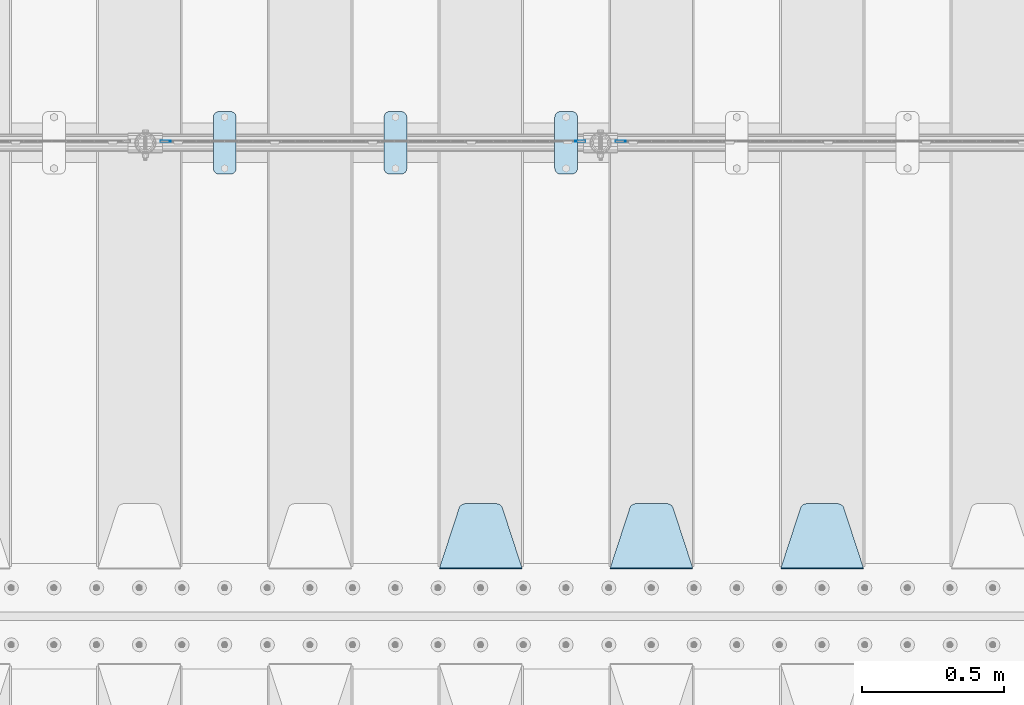
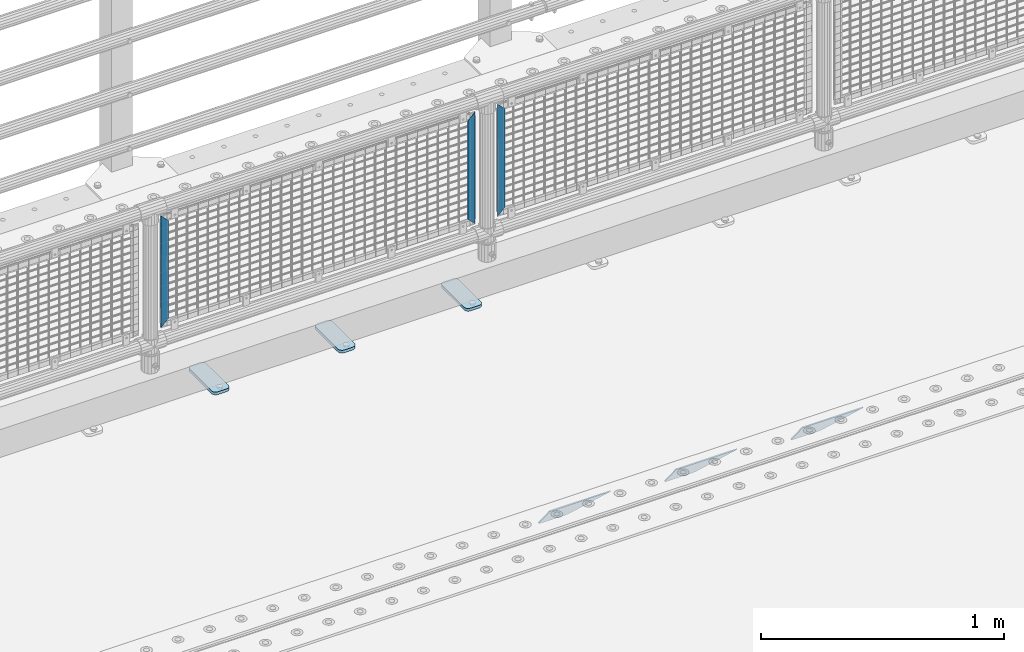
# One storey, part 225 of 257: 9 plates.
"""IFC2X3 building model written with IfcOpenShell, lengths in millimetres."""

from ifc_helpers import new_model, si_unit, frame, origin_with_axes, place, context, subcontext, project, spatial, faceted_brep, material, type_object, element, save


model = new_model("IFC2X3")

# Units and contexts
model_context = context("Model", 3, precision=1e-05, world=origin_with_axes())
body_context = subcontext(model_context, "Body", "Model", "MODEL_VIEW")
ifc_project = project(units=[si_unit("LENGTHUNIT", "METRE", prefix="MILLI"), si_unit("AREAUNIT", "SQUARE_METRE"), si_unit("VOLUMEUNIT", "CUBIC_METRE"), si_unit("MASSUNIT", "GRAM", prefix="KILO"), si_unit("TIMEUNIT", "SECOND"), si_unit("PLANEANGLEUNIT", "RADIAN"), si_unit("SOLIDANGLEUNIT", "STERADIAN"), si_unit("THERMODYNAMICTEMPERATUREUNIT", "DEGREE_CELSIUS"), si_unit("LUMINOUSINTENSITYUNIT", "LUMEN")], contexts=[model_context])

# Site, building, storey
site_placement = place(None, origin_with_axes())
site = spatial("IfcSite", under=ifc_project, at=site_placement, CompositionType="ELEMENT")
building_placement = place(site_placement, origin_with_axes())
building = spatial("IfcBuilding", under=site, at=building_placement, Name="Standard", CompositionType="ELEMENT")
storey_placement = place(building_placement, origin_with_axes())
storey = spatial("IfcBuildingStorey", under=building, at=storey_placement, Name="Undefined", CompositionType="ELEMENT", Elevation=0.0)

# Plates
ifc_material_1 = material(Name="STEEL/S355J2")
plate_type_1 = type_object("IfcPlateType", PredefinedType="NOTDEFINED")
plate_1_placement = place(storey_placement, frame((50910.0, 10774.5, 21.0199999999977), z_axis=(1.0, 0.0, 0.0), x_axis=(0.0, -1.0, 0.0)))
element("IfcPlate", 1, at=plate_1_placement, inside=storey, type_object=plate_type_1, material=ifc_material_1, context=body_context, shape_type="Brep", body=[
    faceted_brep([(0.0, -7.0, 20.0), (0.0, -7.0, 60.0), (0.0, 7.0, 60.0), (0.0, 7.0, 20.0), (0.384294391935327, -7.0, 63.9018064403208), (0.384294391935327, 7.0, 63.9018064403208), (1.52240934977453, -7.0, 67.6536686473046), (1.52240934977453, 7.0, 67.6536686473046), (3.37060775394821, -7.0, 71.1114046603907), (3.37060775394821, 7.0, 71.1114046603907), (5.85786437626848, -7.0, 74.1421356237333), (5.85786437626848, 7.0, 74.1421356237333), (8.88859533960749, -7.0, 76.6293922460536), (8.88859533960749, 7.0, 76.6293922460536), (12.3463313526991, -7.0, 78.4775906502255), (12.3463313526991, 7.0, 78.4775906502255), (16.0981935596774, -7.0, 79.6157056080629), (16.0981935596774, 7.0, 79.6157056080629), (20.0, -7.0, 80.0), (20.0, 7.0, 80.0), (200.0, -7.0, 80.0), (200.0, 7.0, 80.0), (203.901806440323, -7.0, 79.6157056080629), (203.901806440323, 7.0, 79.6157056080629), (207.653668647301, -7.0, 78.4775906502255), (207.653668647301, 7.0, 78.4775906502255), (211.111404660393, -7.0, 76.6293922460536), (211.111404660393, 7.0, 76.6293922460536), (214.142135623732, -7.0, 74.1421356237333), (214.142135623732, 7.0, 74.1421356237333), (216.629392246052, -7.0, 71.1114046603907), (216.629392246052, 7.0, 71.1114046603907), (218.477590650225, -7.0, 67.6536686473046), (218.477590650225, 7.0, 67.6536686473046), (219.615705608065, -7.0, 63.9018064403208), (219.615705608065, 7.0, 63.9018064403208), (220.0, -7.0, 60.0), (220.0, 7.0, 60.0), (220.0, -7.0, 20.0), (220.0, 7.0, 20.0), (219.615705608065, -7.0, 16.0981935596792), (219.615705608065, 7.0, 16.0981935596792), (218.477590650225, -7.0, 12.3463313526954), (218.477590650225, 7.0, 12.3463313526954), (216.629392246052, -7.0, 8.88859533960931), (216.629392246052, 7.0, 8.88859533960931), (214.142135623732, -7.0, 5.85786437626666), (214.142135623732, 7.0, 5.85786437626666), (211.111404660393, -7.0, 3.37060775394639), (211.111404660393, 7.0, 3.37060775394639), (207.653668647301, -7.0, 1.52240934977453), (207.653668647301, 7.0, 1.52240934977453), (203.901806440323, -7.0, 0.384294391937146), (203.901806440323, 7.0, 0.384294391937146), (200.0, -7.0, 0.0), (200.0, 7.0, 0.0), (20.0, -7.0, 0.0), (20.0, 7.0, 0.0), (16.0981935596774, -7.0, 0.384294391937146), (16.0981935596774, 7.0, 0.384294391937146), (12.3463313526991, -7.0, 1.52240934977453), (12.3463313526991, 7.0, 1.52240934977453), (8.88859533960749, -7.0, 3.37060775394639), (8.88859533960749, 7.0, 3.37060775394639), (5.85786437626848, -7.0, 5.85786437626666), (5.85786437626848, 7.0, 5.85786437626666), (3.37060775394821, -7.0, 8.88859533960931), (3.37060775394821, 7.0, 8.88859533960931), (1.52240934977453, -7.0, 12.3463313526954), (1.52240934977453, 7.0, 12.3463313526954), (0.384294391935327, -7.0, 16.0981935596792), (0.384294391935327, 7.0, 16.0981935596792)], [[[0, 1, 2, 3]], [[1, 4, 5, 2]], [[4, 6, 7, 5]], [[6, 8, 9, 7]], [[8, 10, 11, 9]], [[10, 12, 13, 11]], [[12, 14, 15, 13]], [[14, 16, 17, 15]], [[16, 18, 19, 17]], [[18, 20, 21, 19]], [[20, 22, 23, 21]], [[22, 24, 25, 23]], [[24, 26, 27, 25]], [[26, 28, 29, 27]], [[28, 30, 31, 29]], [[30, 32, 33, 31]], [[32, 34, 35, 33]], [[34, 36, 37, 35]], [[36, 38, 39, 37]], [[38, 40, 41, 39]], [[40, 42, 43, 41]], [[42, 44, 45, 43]], [[44, 46, 47, 45]], [[46, 48, 49, 47]], [[48, 50, 51, 49]], [[50, 52, 53, 51]], [[52, 54, 55, 53]], [[54, 56, 57, 55]], [[56, 58, 59, 57]], [[58, 60, 61, 59]], [[60, 62, 63, 61]], [[62, 64, 65, 63]], [[64, 66, 67, 65]], [[66, 68, 69, 67]], [[68, 70, 71, 69]], [[70, 0, 3, 71]], [[5, 7, 9, 11, 13, 15, 17, 19, 21, 23, 25, 27, 29, 31, 33, 35, 37, 39, 41, 43, 45, 47, 49, 51, 53, 55, 57, 59, 61, 63, 65, 67, 69, 71, 3, 2]], [[70, 68, 66, 64, 62, 60, 58, 56, 54, 52, 50, 48, 46, 44, 42, 40, 38, 36, 34, 32, 30, 28, 26, 24, 22, 20, 18, 16, 14, 12, 10, 8, 6, 4, 1, 0]]]),
])
plate_2_placement = place(storey_placement, frame((50310.0, 10774.5, 21.0199999999977), z_axis=(1.0, 0.0, 0.0), x_axis=(0.0, -1.0, 0.0)))
element("IfcPlate", 2, at=plate_2_placement, inside=storey, type_object=plate_type_1, material=ifc_material_1, context=body_context, shape_type="Brep", body=[
    faceted_brep([(0.0, -7.0, 20.0), (0.0, -7.0, 60.0), (0.0, 7.0, 60.0), (0.0, 7.0, 20.0), (0.384294391935327, -7.0, 63.9018064403208), (0.384294391935327, 7.0, 63.9018064403208), (1.52240934977453, -7.0, 67.6536686473046), (1.52240934977453, 7.0, 67.6536686473046), (3.37060775394821, -7.0, 71.1114046603907), (3.37060775394821, 7.0, 71.1114046603907), (5.85786437626848, -7.0, 74.1421356237333), (5.85786437626848, 7.0, 74.1421356237333), (8.88859533960749, -7.0, 76.6293922460536), (8.88859533960749, 7.0, 76.6293922460536), (12.3463313526991, -7.0, 78.4775906502255), (12.3463313526991, 7.0, 78.4775906502255), (16.0981935596774, -7.0, 79.6157056080629), (16.0981935596774, 7.0, 79.6157056080629), (20.0, -7.0, 80.0), (20.0, 7.0, 80.0), (200.0, -7.0, 80.0), (200.0, 7.0, 80.0), (203.901806440323, -7.0, 79.6157056080629), (203.901806440323, 7.0, 79.6157056080629), (207.653668647301, -7.0, 78.4775906502255), (207.653668647301, 7.0, 78.4775906502255), (211.111404660393, -7.0, 76.6293922460536), (211.111404660393, 7.0, 76.6293922460536), (214.142135623732, -7.0, 74.1421356237333), (214.142135623732, 7.0, 74.1421356237333), (216.629392246052, -7.0, 71.1114046603907), (216.629392246052, 7.0, 71.1114046603907), (218.477590650225, -7.0, 67.6536686473046), (218.477590650225, 7.0, 67.6536686473046), (219.615705608065, -7.0, 63.9018064403208), (219.615705608065, 7.0, 63.9018064403208), (220.0, -7.0, 60.0), (220.0, 7.0, 60.0), (220.0, -7.0, 20.0), (220.0, 7.0, 20.0), (219.615705608065, -7.0, 16.0981935596792), (219.615705608065, 7.0, 16.0981935596792), (218.477590650225, -7.0, 12.3463313526954), (218.477590650225, 7.0, 12.3463313526954), (216.629392246052, -7.0, 8.88859533960931), (216.629392246052, 7.0, 8.88859533960931), (214.142135623732, -7.0, 5.85786437626666), (214.142135623732, 7.0, 5.85786437626666), (211.111404660393, -7.0, 3.37060775394639), (211.111404660393, 7.0, 3.37060775394639), (207.653668647301, -7.0, 1.52240934977453), (207.653668647301, 7.0, 1.52240934977453), (203.901806440323, -7.0, 0.384294391937146), (203.901806440323, 7.0, 0.384294391937146), (200.0, -7.0, 0.0), (200.0, 7.0, 0.0), (20.0, -7.0, 0.0), (20.0, 7.0, 0.0), (16.0981935596774, -7.0, 0.384294391937146), (16.0981935596774, 7.0, 0.384294391937146), (12.3463313526991, -7.0, 1.52240934977453), (12.3463313526991, 7.0, 1.52240934977453), (8.88859533960749, -7.0, 3.37060775394639), (8.88859533960749, 7.0, 3.37060775394639), (5.85786437626848, -7.0, 5.85786437626666), (5.85786437626848, 7.0, 5.85786437626666), (3.37060775394821, -7.0, 8.88859533960931), (3.37060775394821, 7.0, 8.88859533960931), (1.52240934977453, -7.0, 12.3463313526954), (1.52240934977453, 7.0, 12.3463313526954), (0.384294391935327, -7.0, 16.0981935596792), (0.384294391935327, 7.0, 16.0981935596792)], [[[0, 1, 2, 3]], [[1, 4, 5, 2]], [[4, 6, 7, 5]], [[6, 8, 9, 7]], [[8, 10, 11, 9]], [[10, 12, 13, 11]], [[12, 14, 15, 13]], [[14, 16, 17, 15]], [[16, 18, 19, 17]], [[18, 20, 21, 19]], [[20, 22, 23, 21]], [[22, 24, 25, 23]], [[24, 26, 27, 25]], [[26, 28, 29, 27]], [[28, 30, 31, 29]], [[30, 32, 33, 31]], [[32, 34, 35, 33]], [[34, 36, 37, 35]], [[36, 38, 39, 37]], [[38, 40, 41, 39]], [[40, 42, 43, 41]], [[42, 44, 45, 43]], [[44, 46, 47, 45]], [[46, 48, 49, 47]], [[48, 50, 51, 49]], [[50, 52, 53, 51]], [[52, 54, 55, 53]], [[54, 56, 57, 55]], [[56, 58, 59, 57]], [[58, 60, 61, 59]], [[60, 62, 63, 61]], [[62, 64, 65, 63]], [[64, 66, 67, 65]], [[66, 68, 69, 67]], [[68, 70, 71, 69]], [[70, 0, 3, 71]], [[5, 7, 9, 11, 13, 15, 17, 19, 21, 23, 25, 27, 29, 31, 33, 35, 37, 39, 41, 43, 45, 47, 49, 51, 53, 55, 57, 59, 61, 63, 65, 67, 69, 71, 3, 2]], [[70, 68, 66, 64, 62, 60, 58, 56, 54, 52, 50, 48, 46, 44, 42, 40, 38, 36, 34, 32, 30, 28, 26, 24, 22, 20, 18, 16, 14, 12, 10, 8, 6, 4, 1, 0]]]),
])
plate_3_placement = place(storey_placement, frame((49710.0, 10774.5, 21.0199999999977), z_axis=(1.0, 0.0, 0.0), x_axis=(0.0, -1.0, 0.0)))
element("IfcPlate", 3, at=plate_3_placement, inside=storey, type_object=plate_type_1, material=ifc_material_1, context=body_context, shape_type="Brep", body=[
    faceted_brep([(0.0, -7.0, 20.0), (0.0, -7.0, 60.0), (0.0, 7.0, 60.0), (0.0, 7.0, 20.0), (0.384294391935327, -7.0, 63.9018064403208), (0.384294391935327, 7.0, 63.9018064403208), (1.52240934977453, -7.0, 67.6536686473046), (1.52240934977453, 7.0, 67.6536686473046), (3.37060775394821, -7.0, 71.1114046603907), (3.37060775394821, 7.0, 71.1114046603907), (5.85786437626848, -7.0, 74.1421356237333), (5.85786437626848, 7.0, 74.1421356237333), (8.88859533960749, -7.0, 76.6293922460536), (8.88859533960749, 7.0, 76.6293922460536), (12.3463313526991, -7.0, 78.4775906502255), (12.3463313526991, 7.0, 78.4775906502255), (16.0981935596774, -7.0, 79.6157056080629), (16.0981935596774, 7.0, 79.6157056080629), (20.0, -7.0, 80.0), (20.0, 7.0, 80.0), (200.0, -7.0, 80.0), (200.0, 7.0, 80.0), (203.901806440323, -7.0, 79.6157056080629), (203.901806440323, 7.0, 79.6157056080629), (207.653668647301, -7.0, 78.4775906502255), (207.653668647301, 7.0, 78.4775906502255), (211.111404660393, -7.0, 76.6293922460536), (211.111404660393, 7.0, 76.6293922460536), (214.142135623732, -7.0, 74.1421356237333), (214.142135623732, 7.0, 74.1421356237333), (216.629392246052, -7.0, 71.1114046603907), (216.629392246052, 7.0, 71.1114046603907), (218.477590650225, -7.0, 67.6536686473046), (218.477590650225, 7.0, 67.6536686473046), (219.615705608065, -7.0, 63.9018064403208), (219.615705608065, 7.0, 63.9018064403208), (220.0, -7.0, 60.0), (220.0, 7.0, 60.0), (220.0, -7.0, 20.0), (220.0, 7.0, 20.0), (219.615705608065, -7.0, 16.0981935596792), (219.615705608065, 7.0, 16.0981935596792), (218.477590650225, -7.0, 12.3463313526954), (218.477590650225, 7.0, 12.3463313526954), (216.629392246052, -7.0, 8.88859533960931), (216.629392246052, 7.0, 8.88859533960931), (214.142135623732, -7.0, 5.85786437626666), (214.142135623732, 7.0, 5.85786437626666), (211.111404660393, -7.0, 3.37060775394639), (211.111404660393, 7.0, 3.37060775394639), (207.653668647301, -7.0, 1.52240934977453), (207.653668647301, 7.0, 1.52240934977453), (203.901806440323, -7.0, 0.384294391937146), (203.901806440323, 7.0, 0.384294391937146), (200.0, -7.0, 0.0), (200.0, 7.0, 0.0), (20.0, -7.0, 0.0), (20.0, 7.0, 0.0), (16.0981935596774, -7.0, 0.384294391937146), (16.0981935596774, 7.0, 0.384294391937146), (12.3463313526991, -7.0, 1.52240934977453), (12.3463313526991, 7.0, 1.52240934977453), (8.88859533960749, -7.0, 3.37060775394639), (8.88859533960749, 7.0, 3.37060775394639), (5.85786437626848, -7.0, 5.85786437626666), (5.85786437626848, 7.0, 5.85786437626666), (3.37060775394821, -7.0, 8.88859533960931), (3.37060775394821, 7.0, 8.88859533960931), (1.52240934977453, -7.0, 12.3463313526954), (1.52240934977453, 7.0, 12.3463313526954), (0.384294391935327, -7.0, 16.0981935596792), (0.384294391935327, 7.0, 16.0981935596792)], [[[0, 1, 2, 3]], [[1, 4, 5, 2]], [[4, 6, 7, 5]], [[6, 8, 9, 7]], [[8, 10, 11, 9]], [[10, 12, 13, 11]], [[12, 14, 15, 13]], [[14, 16, 17, 15]], [[16, 18, 19, 17]], [[18, 20, 21, 19]], [[20, 22, 23, 21]], [[22, 24, 25, 23]], [[24, 26, 27, 25]], [[26, 28, 29, 27]], [[28, 30, 31, 29]], [[30, 32, 33, 31]], [[32, 34, 35, 33]], [[34, 36, 37, 35]], [[36, 38, 39, 37]], [[38, 40, 41, 39]], [[40, 42, 43, 41]], [[42, 44, 45, 43]], [[44, 46, 47, 45]], [[46, 48, 49, 47]], [[48, 50, 51, 49]], [[50, 52, 53, 51]], [[52, 54, 55, 53]], [[54, 56, 57, 55]], [[56, 58, 59, 57]], [[58, 60, 61, 59]], [[60, 62, 63, 61]], [[62, 64, 65, 63]], [[64, 66, 67, 65]], [[66, 68, 69, 67]], [[68, 70, 71, 69]], [[70, 0, 3, 71]], [[5, 7, 9, 11, 13, 15, 17, 19, 21, 23, 25, 27, 29, 31, 33, 35, 37, 39, 41, 43, 45, 47, 49, 51, 53, 55, 57, 59, 61, 63, 65, 67, 69, 71, 3, 2]], [[70, 68, 66, 64, 62, 60, 58, 56, 54, 52, 50, 48, 46, 44, 42, 40, 38, 36, 34, 32, 30, 28, 26, 24, 22, 20, 18, 16, 14, 12, 10, 8, 6, 4, 1, 0]]]),
])
ifc_material_2 = material(Name="STEEL/S355N")
plate_type_2 = type_object("IfcPlateType", PredefinedType="NOTDEFINED")
plate_4_placement = place(storey_placement, frame((51995.0, 9168.23223304703, -1.76776695296758), z_axis=(0.0, 0.707106781186547, -0.707106781186548), x_axis=(-1.0, 0.0, 0.0)))
element("IfcPlate", 4, at=plate_4_placement, inside=storey, type_object=plate_type_2, material=ifc_material_2, context=body_context, shape_type="Brep", body=[
    faceted_brep([(0.0, -2.5, 0.0), (69.345504679477, -2.50000000000091, 300.17173142483), (69.345504679477, 2.5, 300.171731424831), (0.0, 2.5, 0.0), (70.927406119954, -2.50000000000091, 304.8974424154), (70.927406119954, 2.5, 304.8974424154), (73.3818627772271, -2.50000000000091, 309.234538108527), (73.3818627772271, 2.49999999999909, 309.234538108527), (76.6187032999587, -2.5, 313.023683126103), (76.6187032999587, 2.5, 313.023683126103), (80.5190132705029, -2.5, 316.125672595372), (80.5190132705029, 2.5, 316.125672595371), (84.9395038596849, -2.5, 318.426546230476), (84.9395038596849, 2.5, 318.426546230477), (89.7177759439219, -2.5, 319.841774983275), (89.7177759439219, 2.5, 319.841774983275), (94.6782862926484, -2.5, 320.319366455079), (94.6782862926484, 2.5, 320.319366455079), (195.321713707352, -2.5, 320.319366455079), (195.321713707352, 2.5, 320.319366455079), (200.282224056078, -2.5, 319.841774983275), (200.282224056078, 2.49999999999909, 319.841774983275), (205.060496140315, -2.5, 318.426546230476), (205.060496140315, 2.49999999999909, 318.426546230475), (209.480986729497, -2.5, 316.125672595371), (209.480986729497, 2.5, 316.125672595371), (213.381296700041, -2.50000000000091, 313.023683126102), (213.381296700041, 2.5, 313.023683126103), (216.618137222766, -2.50000000000091, 309.234538108527), (216.618137222766, 2.5, 309.234538108527), (219.072593880039, -2.5, 304.897442415399), (219.072593880039, 2.5, 304.897442415399), (220.654495320523, -2.50000000000091, 300.17173142483), (220.654495320523, 2.5, 300.171731424831), (290.0, -2.50000000000091, 0.0), (290.0, 2.5, 9.09494701772928e-13)], [[[0, 1, 2, 3]], [[1, 4, 5, 2]], [[4, 6, 7, 5]], [[6, 8, 9, 7]], [[8, 10, 11, 9]], [[10, 12, 13, 11]], [[12, 14, 15, 13]], [[14, 16, 17, 15]], [[16, 18, 19, 17]], [[18, 20, 21, 19]], [[20, 22, 23, 21]], [[22, 24, 25, 23]], [[24, 26, 27, 25]], [[26, 28, 29, 27]], [[28, 30, 31, 29]], [[30, 32, 33, 31]], [[32, 34, 35, 33]], [[34, 0, 3, 35]], [[5, 7, 9, 11, 13, 15, 17, 19, 21, 23, 25, 27, 29, 31, 33, 35, 3, 2]], [[34, 32, 30, 28, 26, 24, 22, 20, 18, 16, 14, 12, 10, 8, 6, 4, 1, 0]]]),
])
plate_5_placement = place(storey_placement, frame((51395.0, 9168.23223304703, -1.76776695296758), z_axis=(0.0, 0.707106781186547, -0.707106781186548), x_axis=(-1.0, 0.0, 0.0)))
element("IfcPlate", 5, at=plate_5_placement, inside=storey, type_object=plate_type_2, material=ifc_material_2, context=body_context, shape_type="Brep", body=[
    faceted_brep([(0.0, -2.5, 0.0), (69.345504679477, -2.50000000000091, 300.17173142483), (69.345504679477, 2.5, 300.171731424831), (0.0, 2.5, 0.0), (70.927406119954, -2.50000000000091, 304.8974424154), (70.927406119954, 2.5, 304.8974424154), (73.3818627772271, -2.50000000000091, 309.234538108527), (73.3818627772271, 2.49999999999909, 309.234538108527), (76.6187032999587, -2.5, 313.023683126103), (76.6187032999587, 2.5, 313.023683126103), (80.5190132705029, -2.5, 316.125672595372), (80.5190132705029, 2.5, 316.125672595371), (84.9395038596849, -2.5, 318.426546230476), (84.9395038596849, 2.5, 318.426546230477), (89.7177759439219, -2.5, 319.841774983275), (89.7177759439219, 2.5, 319.841774983275), (94.6782862926484, -2.5, 320.319366455079), (94.6782862926484, 2.5, 320.319366455079), (195.321713707352, -2.5, 320.319366455079), (195.321713707352, 2.5, 320.319366455079), (200.282224056078, -2.5, 319.841774983275), (200.282224056078, 2.49999999999909, 319.841774983275), (205.060496140315, -2.5, 318.426546230476), (205.060496140315, 2.49999999999909, 318.426546230475), (209.480986729497, -2.5, 316.125672595371), (209.480986729497, 2.5, 316.125672595371), (213.381296700041, -2.50000000000091, 313.023683126102), (213.381296700041, 2.5, 313.023683126103), (216.618137222766, -2.50000000000091, 309.234538108527), (216.618137222766, 2.5, 309.234538108527), (219.072593880039, -2.5, 304.897442415399), (219.072593880039, 2.5, 304.897442415399), (220.654495320523, -2.50000000000091, 300.17173142483), (220.654495320523, 2.5, 300.171731424831), (290.0, -2.50000000000091, 0.0), (290.0, 2.5, 9.09494701772928e-13)], [[[0, 1, 2, 3]], [[1, 4, 5, 2]], [[4, 6, 7, 5]], [[6, 8, 9, 7]], [[8, 10, 11, 9]], [[10, 12, 13, 11]], [[12, 14, 15, 13]], [[14, 16, 17, 15]], [[16, 18, 19, 17]], [[18, 20, 21, 19]], [[20, 22, 23, 21]], [[22, 24, 25, 23]], [[24, 26, 27, 25]], [[26, 28, 29, 27]], [[28, 30, 31, 29]], [[30, 32, 33, 31]], [[32, 34, 35, 33]], [[34, 0, 3, 35]], [[5, 7, 9, 11, 13, 15, 17, 19, 21, 23, 25, 27, 29, 31, 33, 35, 3, 2]], [[34, 32, 30, 28, 26, 24, 22, 20, 18, 16, 14, 12, 10, 8, 6, 4, 1, 0]]]),
])
plate_6_placement = place(storey_placement, frame((50795.0, 9168.23223304703, -1.76776695296758), z_axis=(0.0, 0.707106781186547, -0.707106781186548), x_axis=(-1.0, 0.0, 0.0)))
element("IfcPlate", 6, at=plate_6_placement, inside=storey, type_object=plate_type_2, material=ifc_material_2, context=body_context, shape_type="Brep", body=[
    faceted_brep([(0.0, -2.5, 0.0), (69.345504679477, -2.50000000000091, 300.17173142483), (69.345504679477, 2.5, 300.171731424831), (0.0, 2.5, 0.0), (70.927406119954, -2.50000000000091, 304.8974424154), (70.927406119954, 2.5, 304.8974424154), (73.3818627772271, -2.50000000000091, 309.234538108527), (73.3818627772271, 2.49999999999909, 309.234538108527), (76.6187032999587, -2.5, 313.023683126103), (76.6187032999587, 2.5, 313.023683126103), (80.5190132705029, -2.5, 316.125672595372), (80.5190132705029, 2.5, 316.125672595371), (84.9395038596849, -2.5, 318.426546230476), (84.9395038596849, 2.5, 318.426546230477), (89.7177759439219, -2.5, 319.841774983275), (89.7177759439219, 2.5, 319.841774983275), (94.6782862926484, -2.5, 320.319366455079), (94.6782862926484, 2.5, 320.319366455079), (195.321713707352, -2.5, 320.319366455079), (195.321713707352, 2.5, 320.319366455079), (200.282224056078, -2.5, 319.841774983275), (200.282224056078, 2.49999999999909, 319.841774983275), (205.060496140315, -2.5, 318.426546230476), (205.060496140315, 2.49999999999909, 318.426546230475), (209.480986729497, -2.5, 316.125672595371), (209.480986729497, 2.5, 316.125672595371), (213.381296700041, -2.50000000000091, 313.023683126102), (213.381296700041, 2.5, 313.023683126103), (216.618137222766, -2.50000000000091, 309.234538108527), (216.618137222766, 2.5, 309.234538108527), (219.072593880039, -2.5, 304.897442415399), (219.072593880039, 2.5, 304.897442415399), (220.654495320523, -2.50000000000091, 300.17173142483), (220.654495320523, 2.5, 300.171731424831), (290.0, -2.50000000000091, 0.0), (290.0, 2.5, 9.09494701772928e-13)], [[[0, 1, 2, 3]], [[1, 4, 5, 2]], [[4, 6, 7, 5]], [[6, 8, 9, 7]], [[8, 10, 11, 9]], [[10, 12, 13, 11]], [[12, 14, 15, 13]], [[14, 16, 17, 15]], [[16, 18, 19, 17]], [[18, 20, 21, 19]], [[20, 22, 23, 21]], [[22, 24, 25, 23]], [[24, 26, 27, 25]], [[26, 28, 29, 27]], [[28, 30, 31, 29]], [[30, 32, 33, 31]], [[32, 34, 35, 33]], [[34, 0, 3, 35]], [[5, 7, 9, 11, 13, 15, 17, 19, 21, 23, 25, 27, 29, 31, 33, 35, 3, 2]], [[34, 32, 30, 28, 26, 24, 22, 20, 18, 16, 14, 12, 10, 8, 6, 4, 1, 0]]]),
])
ifc_material_3 = material(Name="Misc_Undefined")
plate_type_3 = type_object("IfcPlateType", PredefinedType="NOTDEFINED")
for number, where, z_axis, x_axis in (
    (7, (51159.509713541, 10670.5, 879.519963133601), (-0.707008801899317, 0.0, -0.707204746899292), (-0.707204746899293, 0.0, 0.707008801899317)),
    (8, (49559.509713541, 10670.5, 879.519963133601), (-0.707008801899317, 0.0, -0.707204746899292), (-0.707204746899293, 0.0, 0.707008801899317)),
):
    element("IfcPlate", number, at=place(storey_placement, frame(where, z_axis=z_axis, x_axis=x_axis)), inside=storey, type_object=plate_type_3, material=ifc_material_3, context=body_context, shape_type="Brep", body=[
        faceted_brep([(0.0, -1.5, -5.6843418860808e-14), (-348.552185058586, -1.5, 348.655029296868), (-348.552185058586, 1.5, 348.655029296868), (0.0, 1.5, -5.6843418860808e-14), (-348.544891357407, -1.5, 398.152496337891), (-348.544891357407, 1.5, 398.152496337891), (49.5043945312573, -1.5, 7.27595761418343e-11), (49.5043945312573, 1.5, 7.27595761418343e-11)], [[[0, 1, 2, 3]], [[1, 4, 5, 2]], [[4, 6, 7, 5]], [[6, 0, 3, 7]], [[5, 7, 3, 2]], [[6, 4, 1, 0]]]),
    ])
plate_7_placement = place(storey_placement, frame((50982.4996874836, 10670.5, 879.52), z_axis=(0.707103624179501, 0.0, -0.707109938179499), x_axis=(0.707109938179525, 0.0, 0.707103624179475)))
element("IfcPlate", 9, at=plate_7_placement, inside=storey, type_object=plate_type_3, material=ifc_material_3, context=body_context, shape_type="Brep", body=[
    faceted_brep([(0.0, -1.5, -5.6843418860808e-14), (-348.605163574226, -1.5, 348.602081298828), (-348.605163574226, 1.5, 348.602081298828), (0.0, 1.5, -5.6843418860808e-14), (-348.605163574226, -1.5, 398.099334716804), (-348.605163574226, 1.5, 398.099334716804), (49.4976959228443, -1.5, 6.54836185276508e-11), (49.4976959228443, 1.5, 6.54836185276508e-11)], [[[0, 1, 2, 3]], [[1, 4, 5, 2]], [[4, 6, 7, 5]], [[6, 0, 3, 7]], [[5, 7, 3, 2]], [[6, 4, 1, 0]]]),
])

save(model, "model.ifc")
